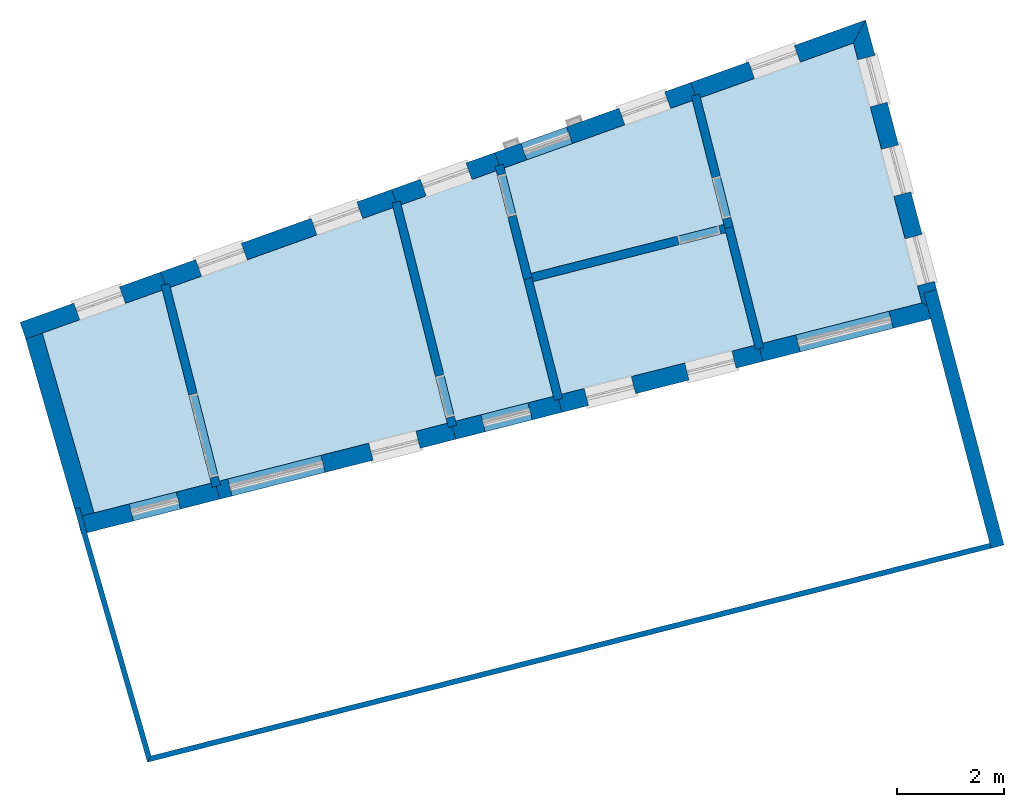
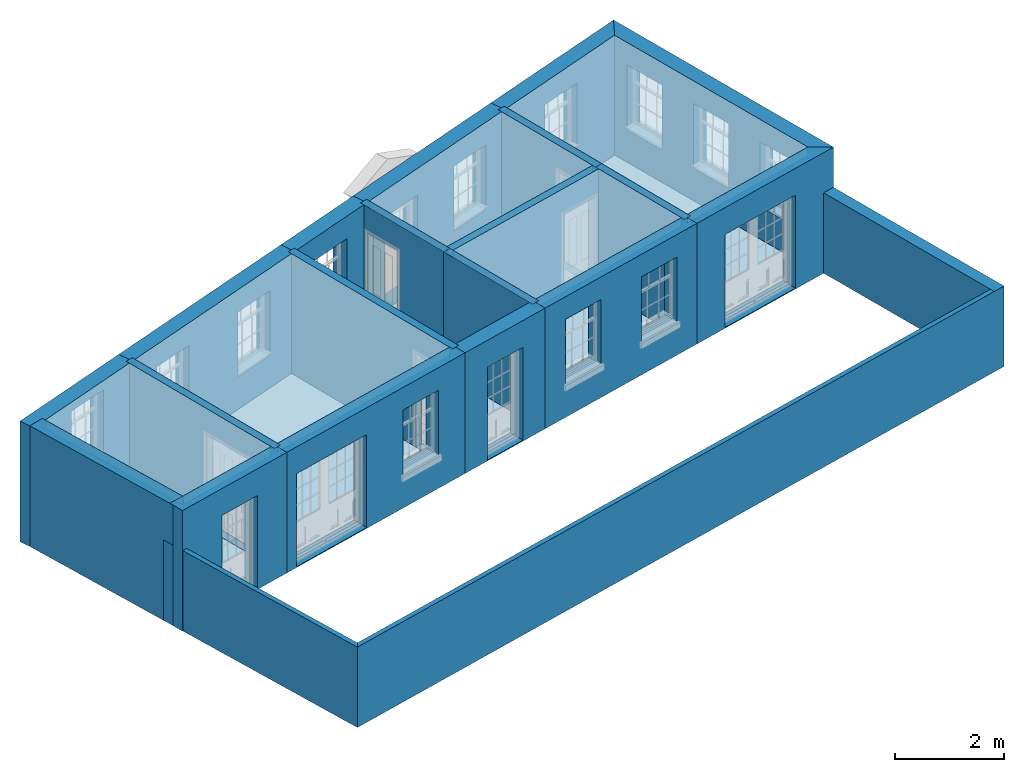
# One storey, part 1 of 15: 22 walls, 11 slabs, 22 openings.
"""IFC2X3 building model written with IfcOpenShell, lengths in metres."""

from ifc_helpers import new_model, si_unit, frame, origin, place, context, subcontext, project, spatial, polyline, outline, extrude, material, layer, layer_set, layer_usage, element, save


model = new_model("IFC2X3")

# Units and contexts
model_context = context("Model", 3, world=origin())
body_context = subcontext(model_context, "Body", "Model", "MODEL_VIEW")
ifc_project = project(units=[si_unit("PLANEANGLEUNIT", "RADIAN"), si_unit("MASSUNIT", "GRAM", prefix="KILO"), si_unit("FORCEUNIT", "NEWTON", prefix="KILO"), si_unit("LENGTHUNIT", "METRE")], contexts=[model_context])

# Site, building, storey
site_placement = place(None, origin())
site = spatial("IfcSite", under=ifc_project, at=site_placement, CompositionType="ELEMENT")
building_placement = place(None, origin())
building = spatial("IfcBuilding", under=site, at=building_placement, Name="Building plot-13", CompositionType="ELEMENT")
storey_placement = place(None, frame((0.0, 0.0, 4.0)))
storey = spatial("IfcBuildingStorey", under=building, at=storey_placement, Name="Floor 0", CompositionType="ELEMENT", Elevation=4.0)

# Slabs
slab_1_placement = place(storey_placement, frame((0.0, 0.0, 2.5)))
element("IfcSlab", 1, at=slab_1_placement, inside=storey, Name="Slab", ObjectType="Slab", PredefinedType="FLOOR", context=body_context, shape_type="SweptSolid", body=[
    extrude(outline(polyline([(65.7552221133169, 47.486064081903), (63.5089556033757, 46.6828633554332), (64.4776980150231, 43.3164713331512), (66.6716163218336, 43.8729084918023), (65.7552221133169, 47.486064081903)])), origin(), (0.0, 0.0, 1.0), 0.2),
])
slab_2_placement = place(storey_placement, frame((0.0, 0.0, 2.5)))
element("IfcSlab", 2, at=slab_2_placement, inside=storey, Name="Slab", ObjectType="Slab", PredefinedType="FLOOR", context=body_context, shape_type="SweptSolid", body=[
    extrude(outline(polyline([(66.8267058597151, 43.9122434030099), (71.0924235909926, 44.9941450611672), (70.0791346157294, 49.0321716554071), (65.9065629771408, 47.5401792508866), (66.8267058597151, 43.9122434030099)])), origin(), (0.0, 0.0, 1.0), 0.2),
])
slab_3_placement = place(storey_placement, frame((0.0, 0.0, 2.5)))
element("IfcSlab", 3, at=slab_3_placement, inside=storey, Name="Slab", ObjectType="Slab", PredefinedType="FLOOR", context=body_context, shape_type="SweptSolid", body=[
    extrude(outline(polyline([(76.9996613749918, 46.4923807054943), (79.9817754258731, 47.2487256724398), (78.699089450727, 52.1144212259562), (75.8336276673544, 51.0898139605717), (76.9996613749918, 46.4923807054943)])), origin(), (0.0, 0.0, 1.0), 0.2),
])
slab_4_placement = place(storey_placement, frame((0.0, 0.0, 2.5)))
element("IfcSlab", 4, at=slab_4_placement, inside=storey, Name="Slab", ObjectType="Slab", PredefinedType="FLOOR", context=body_context, shape_type="SweptSolid", body=[
    extrude(outline(polyline([(72.6989822532658, 47.6460989822379), (73.2338394240791, 45.5372661691657), (76.8445718371103, 46.4530457942866), (76.309714666297, 48.5618786073587), (72.6989822532658, 47.6460989822379)])), origin(), (0.0, 0.0, 1.0), 0.2),
])
slab_5_placement = place(storey_placement, frame((0.0, 0.0, 2.5)))
element("IfcSlab", 5, at=slab_5_placement, inside=storey, Name="Slab", ObjectType="Slab", PredefinedType="FLOOR", context=body_context, shape_type="SweptSolid", body=[
    extrude(outline(polyline([(72.1588295162765, 49.7758111334306), (72.6596473420581, 47.8011885201194), (76.2703797550893, 48.7169681452402), (75.6822868035305, 51.035698791588), (72.1588295162765, 49.7758111334306)])), origin(), (0.0, 0.0, 1.0), 0.2),
])
slab_6_placement = place(storey_placement, origin())
element("IfcSlab", 6, at=slab_6_placement, inside=storey, Name="Slab", ObjectType="Slab", PredefinedType="FLOOR", context=body_context, shape_type="SweptSolid", body=[
    extrude(outline(polyline([(72.1588295162765, 49.7758111334306), (72.6596473420581, 47.8011885201194), (76.2703797550893, 48.7169681452402), (75.6822868035305, 51.035698791588), (72.1588295162765, 49.7758111334306)])), origin(), (0.0, 0.0, 1.0), 0.02),
])
slab_7_placement = place(storey_placement, origin())
element("IfcSlab", 7, at=slab_7_placement, inside=storey, Name="Slab", ObjectType="Slab", PredefinedType="FLOOR", context=body_context, shape_type="SweptSolid", body=[
    extrude(outline(polyline([(66.8267058597151, 43.9122434030099), (71.0924235909926, 44.9941450611672), (70.0791346157294, 49.0321716554071), (65.9065629771408, 47.5401792508866), (66.8267058597151, 43.9122434030099)])), origin(), (0.0, 0.0, 1.0), 0.02),
])
slab_8_placement = place(storey_placement, origin())
element("IfcSlab", 8, at=slab_8_placement, inside=storey, Name="Slab", ObjectType="Slab", PredefinedType="FLOOR", context=body_context, shape_type="SweptSolid", body=[
    extrude(outline(polyline([(70.2305124548434, 49.0863000456981), (71.2475136250127, 45.0334800982092), (73.0787498861976, 45.4979312579581), (72.0074886524525, 49.7216959644469), (70.2305124548434, 49.0863000456981)])), origin(), (0.0, 0.0, 1.0), 0.02),
])
slab_9_placement = place(storey_placement, origin())
element("IfcSlab", 9, at=slab_9_placement, inside=storey, Name="Slab", ObjectType="Slab", PredefinedType="FLOOR", context=body_context, shape_type="SweptSolid", body=[
    extrude(outline(polyline([(76.9996613749918, 46.4923807054943), (79.9817754258731, 47.2487256724398), (78.699089450727, 52.1144212259562), (75.8336276673544, 51.0898139605717), (76.9996613749918, 46.4923807054943)])), origin(), (0.0, 0.0, 1.0), 0.02),
])
slab_10_placement = place(storey_placement, origin())
element("IfcSlab", 10, at=slab_10_placement, inside=storey, Name="Slab", ObjectType="Slab", PredefinedType="FLOOR", context=body_context, shape_type="SweptSolid", body=[
    extrude(outline(polyline([(65.7552221133169, 47.486064081903), (63.5089556033757, 46.6828633554332), (64.4776980150231, 43.3164713331512), (66.6716163218336, 43.8729084918023), (65.7552221133169, 47.486064081903)])), origin(), (0.0, 0.0, 1.0), 0.02),
])
slab_11_placement = place(storey_placement, origin())
element("IfcSlab", 11, at=slab_11_placement, inside=storey, Name="Slab", ObjectType="Slab", PredefinedType="FLOOR", context=body_context, shape_type="SweptSolid", body=[
    extrude(outline(polyline([(72.6989822532658, 47.6460989822379), (73.2338394240791, 45.5372661691657), (76.8445718371103, 46.4530457942866), (76.309714666297, 48.5618786073587), (72.6989822532658, 47.6460989822379)])), origin(), (0.0, 0.0, 1.0), 0.02),
])

# Wall, opening
ifc_material_1 = material(Name="Masonry")
ifc_layer_1 = layer(ifc_material_1, 0.33, ventilated=False)
ifc_layer_set_1 = layer_set([ifc_layer_1], Name="My Wall")
ifc_layer_usage_1 = layer_usage(ifc_layer_set_1, "AXIS2", "NEGATIVE", 0.08)
wall_1_placement = place(storey_placement, origin())
wall_1 = element("IfcWallStandardCase", 12, at=wall_1_placement, inside=storey, material=ifc_layer_usage_1, Name="exterior", context=body_context, shape_type="SweptSolid", body=[
    extrude(outline(polyline([(64.1602540157798, 43.2359589291926), (64.2413822701456, 42.9160867573121), (66.8302893451402, 43.5727037755256), (66.7491610907744, 43.8925759474061), (64.1602540157798, 43.2359589291926)])), origin(), (0.0, 0.0, 1.0), 2.7),
])
opening_1_placement = place(storey_placement, frame((0.0, 0.0, 0.0199999999999996)))
element("IfcOpeningElement", 13, at=opening_1_placement, cuts=wall_1, Name="Opening", ObjectType="Opening", context=body_context, shape_type="SweptSolid", body=[
    extrude(outline(polyline([(65.2159636357624, 43.163267012053), (66.0980353824632, 43.3869843195467), (66.0169071280974, 43.7068564914272), (65.1348353813966, 43.4831391839336), (65.2159636357624, 43.163267012053)])), origin(), (0.0, 0.0, 1.0), 2.08),
])

# Wall, openings
wall_2_placement = place(storey_placement, origin())
wall_2 = element("IfcWallStandardCase", 14, at=wall_2_placement, inside=storey, material=ifc_layer_usage_1, Name="exterior", context=body_context, shape_type="SweptSolid", body=[
    extrude(outline(polyline([(66.7491610907744, 43.8925759474061), (66.8302893451402, 43.5727037755256), (71.2509007169492, 44.6938906600119), (71.1697724625834, 45.0137628318924), (66.7491610907744, 43.8925759474061)])), origin(), (0.0, 0.0, 1.0), 2.7),
])
opening_2_placement = place(storey_placement, frame((0.0, 0.0, 0.0199999999999996)))
element("IfcOpeningElement", 15, at=opening_2_placement, cuts=wall_2, Name="Opening", ObjectType="Opening", context=body_context, shape_type="SweptSolid", body=[
    extrude(outline(polyline([(67.0630635375092, 43.631741621104), (68.8078208386756, 44.0742593721904), (68.7266925843098, 44.3941315440709), (66.9819352831434, 43.9516137929845), (67.0630635375092, 43.631741621104)])), origin(), (0.0, 0.0, 1.0), 2.08),
])
opening_3_placement = place(storey_placement, frame((0.0, 0.0, 0.75)))
element("IfcOpeningElement", 16, at=opening_3_placement, cuts=wall_2, Name="Opening", ObjectType="Opening", context=body_context, shape_type="SweptSolid", body=[
    extrude(outline(polyline([(69.7047120006465, 44.3017352851435), (70.5867837473473, 44.5254525926372), (70.5056554929815, 44.8453247645177), (69.6235837462807, 44.621607457024), (69.7047120006465, 44.3017352851435)])), origin(), (0.0, 0.0, 1.0), 1.445),
])

# Wall, opening
wall_3_placement = place(storey_placement, origin())
wall_3 = element("IfcWallStandardCase", 17, at=wall_3_placement, inside=storey, material=ifc_layer_usage_1, Name="exterior", context=body_context, shape_type="SweptSolid", body=[
    extrude(outline(polyline([(71.1697724625834, 45.0137628318924), (71.2509007169492, 44.6938906600119), (73.2374229095042, 45.1977265416814), (73.1562946551384, 45.5175987135619), (71.1697724625834, 45.0137628318924)])), origin(), (0.0, 0.0, 1.0), 2.7),
])
opening_4_placement = place(storey_placement, frame((0.0, 0.0, 0.0199999999999996)))
element("IfcOpeningElement", 18, at=opening_4_placement, cuts=wall_3, Name="Opening", ObjectType="Opening", context=body_context, shape_type="SweptSolid", body=[
    extrude(outline(polyline([(71.8031259398763, 44.8339499470999), (72.6851976865771, 45.0576672545935), (72.6040694322113, 45.377539426474), (71.7219976855105, 45.1538221189804), (71.8031259398763, 44.8339499470999)])), origin(), (0.0, 0.0, 1.0), 2.08),
])

# Wall, openings
wall_4_placement = place(storey_placement, origin())
wall_4 = element("IfcWallStandardCase", 19, at=wall_4_placement, inside=storey, material=ifc_layer_usage_1, Name="exterior", context=body_context, shape_type="SweptSolid", body=[
    extrude(outline(polyline([(73.1562946551384, 45.5175987135619), (73.2374229095042, 45.1977265416814), (77.0032448604169, 46.1528410780099), (76.9221166060511, 46.4727132498904), (73.1562946551384, 45.5175987135619)])), origin(), (0.0, 0.0, 1.0), 2.7),
])
opening_5_placement = place(storey_placement, frame((0.0, 0.0, 0.75)))
element("IfcOpeningElement", 20, at=opening_5_placement, cuts=wall_4, Name="Opening", ObjectType="Opening", context=body_context, shape_type="SweptSolid", body=[
    extrude(outline(polyline([(73.737842523882, 45.3246465220167), (74.6199142705828, 45.5483638295104), (74.5387860162169, 45.8682360013909), (73.6567142695161, 45.6445186938972), (73.737842523882, 45.3246465220167)])), origin(), (0.0, 0.0, 1.0), 1.445),
])
opening_6_placement = place(storey_placement, frame((0.0, 0.0, 0.75)))
element("IfcOpeningElement", 21, at=opening_6_placement, cuts=wall_4, Name="Opening", ObjectType="Opening", context=body_context, shape_type="SweptSolid", body=[
    extrude(outline(polyline([(75.6207534993383, 45.802203790181), (76.5028252460391, 46.0259210976746), (76.4216969916733, 46.3457932695551), (75.5396252449725, 46.1220759620615), (75.6207534993383, 45.802203790181)])), origin(), (0.0, 0.0, 1.0), 1.445),
])

# Wall, opening
wall_5_placement = place(storey_placement, origin())
wall_5 = element("IfcWallStandardCase", 22, at=wall_5_placement, inside=storey, material=ifc_layer_usage_1, Name="exterior", context=body_context, shape_type="SweptSolid", body=[
    extrude(outline(polyline([(76.9221166060511, 46.4727132498904), (77.0032448604169, 46.1528410780099), (80.3857854678444, 47.0107450750622), (79.9817754258731, 47.2487256724398), (76.9221166060511, 46.4727132498904)])), origin(), (0.0, 0.0, 1.0), 2.7),
])
opening_7_placement = place(storey_placement, frame((0.0, 0.0, 0.0199999999999996)))
element("IfcOpeningElement", 23, at=opening_7_placement, cuts=wall_5, Name="Opening", ObjectType="Opening", context=body_context, shape_type="SweptSolid", body=[
    extrude(outline(polyline([(77.6998328061211, 46.3295146651964), (79.4445901072876, 46.7720324162827), (79.3634618529217, 47.0919045881632), (77.6187045517553, 46.6493868370769), (77.6998328061211, 46.3295146651964)])), origin(), (0.0, 0.0, 1.0), 2.08),
])

# Wall, openings
wall_6_placement = place(storey_placement, origin())
wall_6 = element("IfcWallStandardCase", 24, at=wall_6_placement, inside=storey, material=ifc_layer_usage_1, Name="exterior", context=body_context, shape_type="SweptSolid", body=[
    extrude(outline(polyline([(79.9817754258731, 47.2487256724398), (80.3857854678444, 47.0107450750622), (78.9265356735152, 52.5462115674965), (78.699089450727, 52.1144212259562), (79.9817754258731, 47.2487256724398)])), origin(), (0.0, 0.0, 1.0), 2.7),
])
opening_8_placement = place(storey_placement, frame((0.0, 0.0, 0.75)))
element("IfcOpeningElement", 25, at=opening_8_placement, cuts=wall_6, Name="Opening", ObjectType="Opening", context=body_context, shape_type="SweptSolid", body=[
    extrude(outline(polyline([(80.2165274414276, 47.6528024784256), (79.9845597414815, 48.5327405365761), (79.6654613247896, 48.4486203816506), (79.8974290247357, 47.5686823235001), (80.2165274414276, 47.6528024784256)])), origin(), (0.0, 0.0, 1.0), 1.445),
])
opening_9_placement = place(storey_placement, frame((0.0, 0.0, 0.75)))
element("IfcOpeningElement", 26, at=opening_9_placement, cuts=wall_6, Name="Opening", ObjectType="Opening", context=body_context, shape_type="SweptSolid", body=[
    extrude(outline(polyline([(79.7746976663439, 49.3288239004194), (79.5427299663978, 50.2087619585699), (79.2236315497059, 50.1246418036444), (79.455599249652, 49.2447037454939), (79.7746976663439, 49.3288239004194)])), origin(), (0.0, 0.0, 1.0), 1.445),
])
opening_10_placement = place(storey_placement, frame((0.0, 0.0, 0.75)))
element("IfcOpeningElement", 27, at=opening_10_placement, cuts=wall_6, Name="Opening", ObjectType="Opening", context=body_context, shape_type="SweptSolid", body=[
    extrude(outline(polyline([(79.3328678912602, 51.0048453224131), (79.1009001913141, 51.8847833805637), (78.7818017746222, 51.8006632256382), (79.0137694745683, 50.9207251674876), (79.3328678912602, 51.0048453224131)])), origin(), (0.0, 0.0, 1.0), 1.445),
])

# Wall, opening
wall_7_placement = place(storey_placement, origin())
wall_7 = element("IfcWallStandardCase", 28, at=wall_7_placement, inside=storey, material=ifc_layer_usage_1, Name="exterior", context=body_context, shape_type="SweptSolid", body=[
    extrude(outline(polyline([(78.699089450727, 52.1144212259562), (78.9265356735152, 52.5462115674965), (75.6540271002417, 51.3760559996695), (75.765136209946, 51.0653233722537), (78.699089450727, 52.1144212259562)])), origin(), (0.0, 0.0, 1.0), 2.7),
])
opening_11_placement = place(storey_placement, frame((0.0, 0.0, 0.75)))
element("IfcOpeningElement", 29, at=opening_11_placement, cuts=wall_7, Name="Opening", ObjectType="Opening", context=body_context, shape_type="SweptSolid", body=[
    extrude(outline(polyline([(77.5904751108561, 52.0684744825221), (76.7336063504065, 51.7620826951557), (76.8447154601108, 51.4513500677399), (77.7015842205604, 51.7577418551063), (77.5904751108561, 52.0684744825221)])), origin(), (0.0, 0.0, 1.0), 1.445),
])

# Wall, openings
wall_8_placement = place(storey_placement, origin())
wall_8 = element("IfcWallStandardCase", 30, at=wall_8_placement, inside=storey, material=ifc_layer_usage_1, Name="exterior", context=body_context, shape_type="SweptSolid", body=[
    extrude(outline(polyline([(75.765136209946, 51.0653233722537), (75.6540271002417, 51.3760559996695), (71.9792289491637, 50.0620531725284), (72.090338058868, 49.7513205451126), (75.765136209946, 51.0653233722537)])), origin(), (0.0, 0.0, 1.0), 2.7),
])
opening_12_placement = place(storey_placement, frame((0.0, 0.0, 0.75)))
element("IfcOpeningElement", 31, at=opening_12_placement, cuts=wall_8, Name="Opening", ObjectType="Opening", context=body_context, shape_type="SweptSolid", body=[
    extrude(outline(polyline([(75.163761942697, 51.2007511865675), (74.3068931822474, 50.894359399201), (74.4180022919517, 50.5836267717852), (75.2748710524013, 50.8900185591517), (75.163761942697, 51.2007511865675)])), origin(), (0.0, 0.0, 1.0), 1.445),
])
opening_13_placement = place(storey_placement, frame((0.0, 0.0, 0.0199999999999996)))
element("IfcOpeningElement", 32, at=opening_13_placement, cuts=wall_8, Name="Opening", ObjectType="Opening", context=body_context, shape_type="SweptSolid", body=[
    extrude(outline(polyline([(73.326362867158, 50.5437497729969), (72.4694941067084, 50.2373579856305), (72.5806032164127, 49.9266253582147), (73.4374719768623, 50.2330171455811), (73.326362867158, 50.5437497729969)])), origin(), (0.0, 0.0, 1.0), 2.08),
])

# Wall, opening
wall_9_placement = place(storey_placement, origin())
wall_9 = element("IfcWallStandardCase", 33, at=wall_9_placement, inside=storey, material=ifc_layer_usage_1, Name="exterior", context=body_context, shape_type="SweptSolid", body=[
    extrude(outline(polyline([(72.090338058868, 49.7513205451126), (71.9792289491637, 50.0620531725284), (70.0510857180657, 49.3726042415572), (70.16219482777, 49.0618716141414), (72.090338058868, 49.7513205451126)])), origin(), (0.0, 0.0, 1.0), 2.7),
])
opening_14_placement = place(storey_placement, frame((0.0, 0.0, 0.75)))
element("IfcOpeningElement", 34, at=opening_14_placement, cuts=wall_9, Name="Opening", ObjectType="Opening", context=body_context, shape_type="SweptSolid", body=[
    extrude(outline(polyline([(71.4435917138395, 49.870524600726), (70.5867229533899, 49.5641328133596), (70.6978320630942, 49.2534001859438), (71.5547008235438, 49.5597919733102), (71.4435917138395, 49.870524600726)])), origin(), (0.0, 0.0, 1.0), 1.445),
])

# Wall, openings
wall_10_placement = place(storey_placement, origin())
wall_10 = element("IfcWallStandardCase", 35, at=wall_10_placement, inside=storey, material=ifc_layer_usage_1, Name="exterior", context=body_context, shape_type="SweptSolid", body=[
    extrude(outline(polyline([(70.16219482777, 49.0618716141414), (70.0510857180657, 49.3726042415572), (65.7269624100281, 47.8264212899844), (65.8380715197324, 47.5156886625686), (70.16219482777, 49.0618716141414)])), origin(), (0.0, 0.0, 1.0), 2.7),
])
opening_15_placement = place(storey_placement, frame((0.0, 0.0, 0.75)))
element("IfcOpeningElement", 36, at=opening_15_placement, cuts=wall_10, Name="Opening", ObjectType="Opening", context=body_context, shape_type="SweptSolid", body=[
    extrude(outline(polyline([(69.3984892712811, 49.1392543973472), (68.5416205108315, 48.8328626099808), (68.6527296205358, 48.522129982565), (69.5095983809854, 48.8285217699314), (69.3984892712811, 49.1392543973472)])), origin(), (0.0, 0.0, 1.0), 1.445),
])
opening_16_placement = place(storey_placement, frame((0.0, 0.0, 0.75)))
element("IfcOpeningElement", 37, at=opening_16_placement, cuts=wall_10, Name="Opening", ObjectType="Opening", context=body_context, shape_type="SweptSolid", body=[
    extrude(outline(polyline([(67.2364276172623, 48.3661629215608), (66.3795588568127, 48.0597711341944), (66.490667966517, 47.7490385067786), (67.3475367269666, 48.055430294145), (67.2364276172623, 48.3661629215608)])), origin(), (0.0, 0.0, 1.0), 1.445),
])

# Wall, opening
wall_11_placement = place(storey_placement, origin())
wall_11 = element("IfcWallStandardCase", 38, at=wall_11_placement, inside=storey, material=ifc_layer_usage_1, Name="exterior", context=body_context, shape_type="SweptSolid", body=[
    extrude(outline(polyline([(65.8380715197324, 47.5156886625686), (65.7269624100281, 47.8264212899844), (63.0917307447464, 46.8841377369854), (63.2028398544507, 46.5734051095696), (65.8380715197324, 47.5156886625686)])), origin(), (0.0, 0.0, 1.0), 2.7),
])
opening_17_placement = place(storey_placement, frame((0.0, 0.0, 1.05)))
element("IfcOpeningElement", 39, at=opening_17_placement, cuts=wall_11, Name="Opening", ObjectType="Opening", context=body_context, shape_type="SweptSolid", body=[
    extrude(outline(polyline([(64.955482710421, 47.550562191147), (64.0986139499715, 47.2441704037806), (64.2097230596758, 46.9334377763648), (65.0665918201253, 47.2398295637312), (64.955482710421, 47.550562191147)])), origin(), (0.0, 0.0, 1.0), 1.445),
])

# Walls
wall_12_placement = place(storey_placement, origin())
element("IfcWallStandardCase", 40, at=wall_12_placement, inside=storey, material=ifc_layer_usage_1, Name="party", context=body_context, shape_type="SweptSolid", body=[
    extrude(outline(polyline([(63.4881878736673, 46.7550314764637), (63.1710576453687, 46.6637713082673), (64.1819987013699, 43.150738467956), (64.4991289296685, 43.2419986361524), (63.4881878736673, 46.7550314764637)])), origin(), (0.0, 0.0, 1.0), 2.7),
])
ifc_material_2 = material(Name="Masonry")
ifc_layer_2 = layer(ifc_material_2, 0.16, ventilated=False)
ifc_layer_set_2 = layer_set([ifc_layer_2], Name="My Wall")
ifc_layer_usage_2 = layer_usage(ifc_layer_set_2, "AXIS2", "NEGATIVE", 0.08)
wall_13_placement = place(storey_placement, origin())
element("IfcWallStandardCase", 41, at=wall_13_placement, inside=storey, material=ifc_layer_usage_2, Name="interior", context=body_context, shape_type="SweptSolid", body=[
    extrude(outline(polyline([(76.4451367485746, 48.6787582875071), (76.2900472106932, 48.6394233762995), (76.8642392927142, 46.3755010253459), (77.0193288305956, 46.4148359365535), (76.4451367485746, 48.6787582875071)])), origin(), (0.0, 0.0, 1.0), 2.7),
])

# Wall, opening
wall_14_placement = place(storey_placement, origin())
wall_14 = element("IfcWallStandardCase", 42, at=wall_14_placement, inside=storey, material=ifc_layer_usage_2, Name="interior", context=body_context, shape_type="SweptSolid", body=[
    extrude(outline(polyline([(72.5242252597805, 47.684308839971), (72.6793147976619, 47.7236437511786), (72.1409472860622, 49.8463171225142), (71.9858577481808, 49.8069822113066), (72.5242252597805, 47.684308839971)])), origin(), (0.0, 0.0, 1.0), 2.7),
])
opening_18_placement = place(storey_placement, frame((0.0, 0.0, 0.0199999999999996)))
element("IfcOpeningElement", 43, at=opening_18_placement, cuts=wall_14, Name="Opening", ObjectType="Opening", context=body_context, shape_type="SweptSolid", body=[
    extrude(outline(polyline([(72.3818736172093, 48.8963937029903), (72.1851990611709, 49.6718413923976), (72.0301095232894, 49.6325064811899), (72.2267840793278, 48.8570587917826), (72.3818736172093, 48.8963937029903)])), origin(), (0.0, 0.0, 1.0), 2.1),
])

# Wall
wall_15_placement = place(storey_placement, origin())
element("IfcWallStandardCase", 44, at=wall_15_placement, inside=storey, material=ifc_layer_usage_2, Name="interior", context=body_context, shape_type="SweptSolid", body=[
    extrude(outline(polyline([(72.6793147976619, 47.7236437511786), (72.5242252597805, 47.684308839971), (73.0984173418015, 45.4203864890174), (73.2535068796829, 45.459721400225), (72.6793147976619, 47.7236437511786)])), origin(), (0.0, 0.0, 1.0), 2.7),
])

# Wall, opening
wall_16_placement = place(storey_placement, origin())
wall_16 = element("IfcWallStandardCase", 45, at=wall_16_placement, inside=storey, material=ifc_layer_usage_2, Name="interior", context=body_context, shape_type="SweptSolid", body=[
    extrude(outline(polyline([(71.1118456496785, 44.9167468150566), (71.267034186696, 44.9556893108468), (70.2128535545322, 49.1566719838343), (70.0576650175148, 49.1177294880441), (71.1118456496785, 44.9167468150566)])), origin(), (0.0, 0.0, 1.0), 2.7),
])
opening_19_placement = place(storey_placement, frame((0.0, 0.0, 0.0199999999999996)))
element("IfcOpeningElement", 46, at=opening_19_placement, cuts=wall_16, Name="Opening", ObjectType="Opening", context=body_context, shape_type="SweptSolid", body=[
    extrude(outline(polyline([(71.2232238789319, 45.1302764149915), (71.0285113999808, 45.9062191000789), (70.8733228629633, 45.8672766042887), (71.0680353419145, 45.0913339192013), (71.2232238789319, 45.1302764149915)])), origin(), (0.0, 0.0, 1.0), 2.1),
])

wall_17_placement = place(storey_placement, origin())
wall_17 = element("IfcWallStandardCase", 47, at=wall_17_placement, inside=storey, material=ifc_layer_usage_2, Name="interior", context=body_context, shape_type="SweptSolid", body=[
    extrude(outline(polyline([(66.6912837774375, 43.7953637228616), (66.8463733153189, 43.8346986340692), (65.8886807469266, 47.6106852399702), (65.7335912090452, 47.5713503287626), (66.6912837774375, 43.7953637228616)])), origin(), (0.0, 0.0, 1.0), 2.7),
])
opening_20_placement = place(storey_placement, frame((0.0, 0.0, 0.0199999999999996)))
element("IfcOpeningElement", 48, at=opening_20_placement, cuts=wall_17, Name="Opening", ObjectType="Opening", context=body_context, shape_type="SweptSolid", body=[
    extrude(outline(polyline([(66.8021215402103, 44.0091743641859), (66.4087724281336, 45.5600697430005), (66.2536828902521, 45.5207348317928), (66.6470320023288, 43.9698394529782), (66.8021215402103, 44.0091743641859)])), origin(), (0.0, 0.0, 1.0), 2.1),
])

wall_18_placement = place(storey_placement, origin())
wall_18 = element("IfcWallStandardCase", 49, at=wall_18_placement, inside=storey, material=ifc_layer_usage_2, Name="interior", context=body_context, shape_type="SweptSolid", body=[
    extrude(outline(polyline([(76.3872594352377, 48.5815460629626), (76.3479245240301, 48.736635600844), (72.5821025731174, 47.7815210645155), (72.621437484325, 47.6264315266341), (76.3872594352377, 48.5815460629626)])), origin(), (0.0, 0.0, 1.0), 2.7),
])
opening_21_placement = place(storey_placement, frame((0.0, 0.0, 0.0199999999999996)))
element("IfcOpeningElement", 50, at=opening_21_placement, cuts=wall_18, Name="Opening", ObjectType="Opening", context=body_context, shape_type="SweptSolid", body=[
    extrude(outline(polyline([(76.1734487939134, 48.6923838257354), (75.3980011045061, 48.495709269697), (75.4373360157138, 48.3406197318156), (76.2127837051211, 48.5372942878539), (76.1734487939134, 48.6923838257354)])), origin(), (0.0, 0.0, 1.0), 2.1),
])

wall_19_placement = place(storey_placement, origin())
wall_19 = element("IfcWallStandardCase", 51, at=wall_19_placement, inside=storey, material=ifc_layer_usage_2, Name="interior", context=body_context, shape_type="SweptSolid", body=[
    extrude(outline(polyline([(76.2900472106932, 48.6394233762995), (76.4451367485746, 48.6787582875071), (75.8157454371402, 51.1603199496553), (75.6606558992588, 51.1209850384477), (76.2900472106932, 48.6394233762995)])), origin(), (0.0, 0.0, 1.0), 2.7),
])
opening_22_placement = place(storey_placement, frame((0.0, 0.0, 0.0199999999999996)))
element("IfcOpeningElement", 52, at=opening_22_placement, cuts=wall_19, Name="Opening", ObjectType="Opening", context=body_context, shape_type="SweptSolid", body=[
    extrude(outline(polyline([(76.400884973466, 48.8532340176238), (76.2042104174276, 49.6286817070311), (76.0491208795462, 49.5893467958234), (76.2457954355845, 48.8138991064161), (76.400884973466, 48.8532340176238)])), origin(), (0.0, 0.0, 1.0), 2.1),
])

# Walls
ifc_material_3 = material(Name="Masonry")
ifc_layer_3 = layer(ifc_material_3, 0.1, ventilated=False)
ifc_layer_set_3 = layer_set([ifc_layer_3], Name="My Wall")
ifc_layer_usage_3 = layer_usage(ifc_layer_set_3, "AXIS2", "NEGATIVE", -0.15)
wall_20_placement = place(storey_placement, origin())
element("IfcWallStandardCase", 53, at=wall_20_placement, inside=storey, material=ifc_layer_usage_3, Name="fence", context=body_context, shape_type="SweptSolid", body=[
    extrude(outline(polyline([(64.2089622794934, 43.4186432373327), (64.112862210312, 43.3909886409096), (65.478192562525, 38.6464485544967), (65.5475039883997, 38.7671940221682), (64.2089622794934, 43.4186432373327)])), origin(), (0.0, 0.0, 1.0), 1.8),
])
wall_21_placement = place(storey_placement, origin())
element("IfcWallStandardCase", 54, at=wall_21_placement, inside=storey, material=ifc_layer_usage_3, Name="fence", context=body_context, shape_type="SweptSolid", body=[
    extrude(outline(polyline([(65.5475039883997, 38.7671940221682), (65.478192562525, 38.6464485544967), (81.516032321994, 42.7140794954294), (81.4914480024892, 42.8110104566053), (65.5475039883997, 38.7671940221682)])), origin(), (0.0, 0.0, 1.0), 1.8),
])
ifc_material_4 = material(Name="Masonry")
ifc_layer_4 = layer(ifc_material_4, 0.25, ventilated=False)
ifc_layer_set_4 = layer_set([ifc_layer_4], Name="My Wall")
ifc_layer_usage_4 = layer_usage(ifc_layer_set_4, "AXIS2", "NEGATIVE", 0.0)
wall_22_placement = place(storey_placement, origin())
element("IfcWallStandardCase", 55, at=wall_22_placement, inside=storey, material=ifc_layer_usage_4, Name="fence", context=body_context, shape_type="SweptSolid", body=[
    extrude(outline(polyline([(81.2759715103873, 42.6532048748406), (81.5177127351539, 42.7169322649357), (80.2577310889014, 47.4965020212706), (80.0159898641347, 47.4327746311755), (81.2759715103873, 42.6532048748406)])), origin(), (0.0, 0.0, 1.0), 1.8),
])

save(model, "model.ifc")
